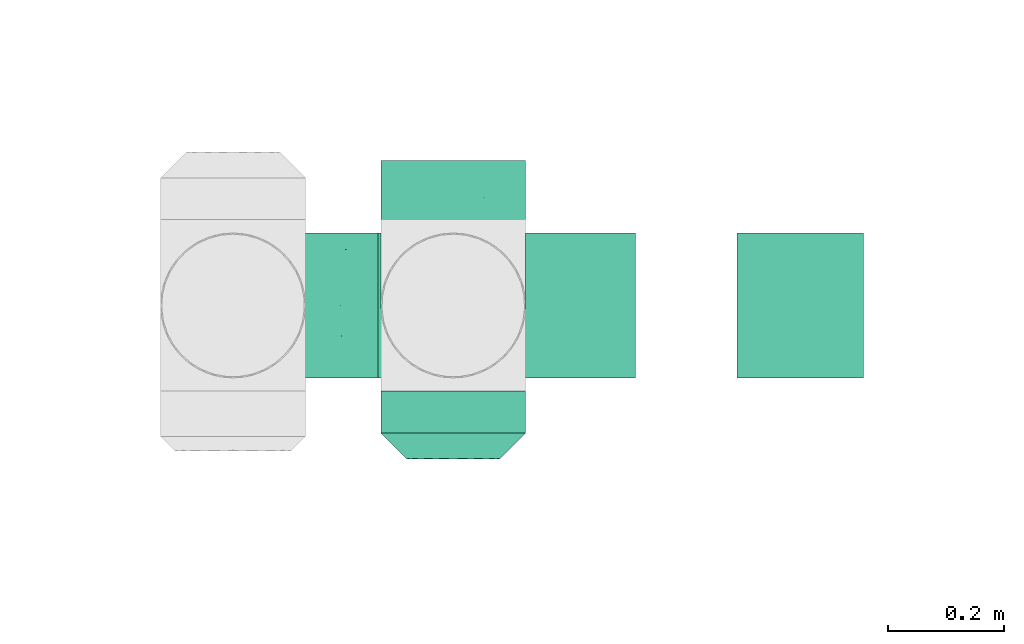
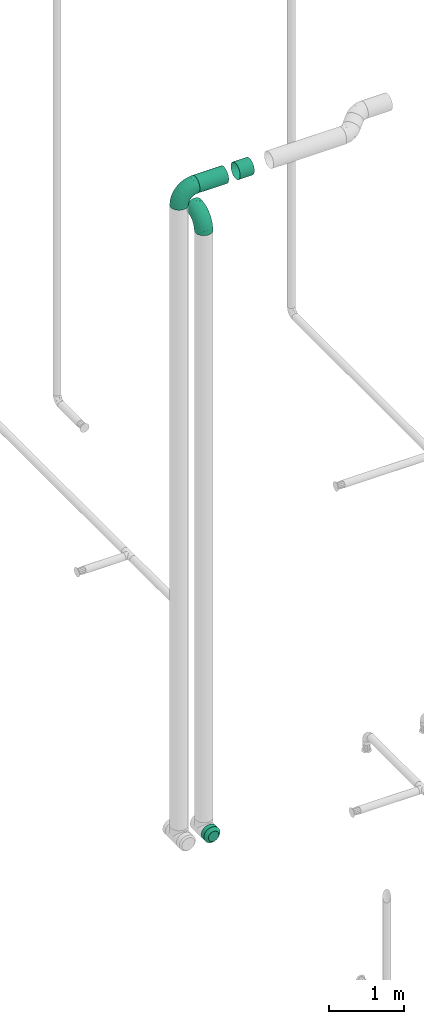
# One storey, part 48 of 123: 3 flow fittings, 2 flow segments.
"""IFC2X3 building model written with IfcOpenShell, lengths in millimetres."""

from ifc_helpers import new_model, entity, si_unit, converted_unit, derived_unit, direction, frame, origin_with_axes, origin_2d_with_axis, place, context, subcontext, project, spatial, hollow_circle, extrude, open_shell, surface_model, source, transform, mapped, material, layer, layer_set, layer_usage, type_object, element, save


model = new_model("IFC2X3")

# Units and contexts
model_context = context("Model", 3, precision=1e-05, world=origin_with_axes(), true_north=direction((0.0, 1.0)))
body_context = subcontext(model_context, "Body", "Model", "MODEL_VIEW")
ifc_project = project(units=[si_unit("AREAUNIT", "SQUARE_METRE"), si_unit("VOLUMEUNIT", "CUBIC_METRE", prefix="DECI"), si_unit("TIMEUNIT", "SECOND"), si_unit("THERMODYNAMICTEMPERATUREUNIT", "DEGREE_CELSIUS"), si_unit("PRESSUREUNIT", "PASCAL"), si_unit("MASSUNIT", "GRAM", prefix="KILO"), si_unit("LENGTHUNIT", "METRE", prefix="MILLI"), si_unit("POWERUNIT", "WATT"), si_unit("ELECTRICCURRENTUNIT", "AMPERE"), si_unit("ELECTRICVOLTAGEUNIT", "VOLT"), derived_unit("VOLUMETRICFLOWRATEUNIT", [(si_unit("VOLUMEUNIT", "CUBIC_METRE", prefix="DECI"), 1), (si_unit("TIMEUNIT", "SECOND"), -1)]), derived_unit("LINEARVELOCITYUNIT", [(si_unit("LENGTHUNIT", "METRE"), 1), (si_unit("TIMEUNIT", "SECOND"), -1)]), derived_unit("MASSDENSITYUNIT", [(si_unit("MASSUNIT", "GRAM", prefix="KILO"), 1), (si_unit("VOLUMEUNIT", "CUBIC_METRE"), -1)]), converted_unit("PLANEANGLEUNIT", "DEGREE", entity("IfcRatioMeasure", 0.01745), si_unit("PLANEANGLEUNIT", "RADIAN"), dimensions=[0, 0, 0, 0, 0, 0, 0])], contexts=[model_context])

# Site, building, storey
site_placement = place(None, origin_with_axes())
site = spatial("IfcSite", under=ifc_project, at=site_placement, CompositionType="ELEMENT")
building_placement = place(site_placement, origin_with_axes())
building = spatial("IfcBuilding", under=site, at=building_placement, Name="mc-building", CompositionType="ELEMENT")
storey_placement = place(building_placement, origin_with_axes())
storey = spatial("IfcBuildingStorey", under=building, at=storey_placement, Name="1. Korrus", CompositionType="ELEMENT", Elevation=0.0)

# Flow fittings
duct_fitting_type_1 = type_object("IfcDuctFittingType", PredefinedType="TRANSITION")
shared_shape_1 = source(origin_with_axes(), body_context, "Body", "SurfaceModel", [
    surface_model("IfcShellBasedSurfaceModel", [(117.0, 73.91036, -30.61467), (117.0, 30.61467, 73.91036), (117.0, 0.0, 80.0), (117.0, -30.61467, 73.91036), (117.0, -80.0, 0.0), (117.0, -56.56854, 56.56854), (117.0, 73.91036, 30.61467), (117.0, 56.56854, 56.56854), (117.0, 80.0, 0.0), (117.0, -73.91036, 30.61467), (117.0, -73.91036, -30.61467), (117.0, -56.56854, -56.56854), (117.0, 0.0, -80.0), (117.0, -30.61467, -73.91036), (117.0, 56.56854, -56.56854), (117.0, 30.61467, -73.91036), (72.0, 125.0, 0.0), (72.0, -38.62713, 118.88206), (72.0, 0.0, 125.0), (72.0, 73.47315, 101.12712), (72.0, 38.62713, 118.88206), (72.0, 101.12712, 73.47315), (72.0, -101.12712, 73.47315), (72.0, -73.47315, 101.12712), (72.0, -118.88206, -38.62713), (72.0, -118.88206, 38.62713), (72.0, -125.0, 0.0), (72.0, 118.88206, 38.62713), (72.0, 118.88206, -38.62713), (72.0, -38.62713, -118.88206), (72.0, 73.47315, -101.12712), (72.0, 101.12712, -73.47315), (72.0, 0.0, -125.0), (72.0, 38.62713, -118.88206), (72.0, -101.12712, -73.47315), (72.0, -73.47315, -101.12712), (117.0, 76.95518, -15.30734), (117.0, 43.59161, -65.23945), (117.0, -43.59161, -65.23945), (117.0, 15.30734, -76.95518), (117.0, 65.23945, -43.59161), (117.0, -15.30734, -76.95518), (117.0, -65.23945, -43.59161), (117.0, -76.95518, -15.30734), (117.0, -76.95518, 15.30734), (117.0, -43.59161, 65.23945), (117.0, 43.59161, 65.23945), (117.0, -15.30734, 76.95518), (117.0, -65.23945, 43.59161), (117.0, 15.30734, 76.95518), (117.0, 65.23945, 43.59161), (117.0, 76.95518, 15.30734), (117.0, 20.70552, -77.27406), (117.0, 40.0, -69.28203), (117.0, 69.28203, -40.0), (117.0, 77.27406, -20.70552), (117.0, -77.27406, -20.70552), (117.0, -20.70552, -77.27406), (117.0, -40.0, -69.28203), (117.0, -69.28203, -40.0), (117.0, 69.28203, 40.0), (117.0, 40.0, 69.28203), (117.0, 20.70552, 77.27406), (117.0, -77.27406, 20.70552), (117.0, -69.28203, 40.0), (117.0, -40.0, 69.28203), (117.0, -20.70552, 77.27406), (117.0, 77.27406, 20.70552), (115.0, 0.0, 80.0), (115.0, 20.70552, 77.27406), (115.0, 40.0, 69.28203), (115.0, -80.0, 0.0), (115.0, 56.56854, 56.56854), (115.0, 69.28203, -40.0), (115.0, 69.28203, 40.0), (115.0, -20.70552, 77.27406), (115.0, -56.56854, 56.56854), (115.0, -40.0, 69.28203), (115.0, -77.27406, 20.70552), (115.0, -69.28203, 40.0), (115.0, 77.27406, 20.70552), (115.0, 80.0, 0.0), (115.0, 77.27406, -20.70552), (115.0, -77.27406, -20.70552), (115.0, 56.56854, -56.56854), (115.0, 40.0, -69.28203), (115.0, 20.70552, -77.27406), (115.0, -56.56854, -56.56854), (115.0, -69.28203, -40.0), (115.0, -20.70552, -77.27406), (115.0, -40.0, -69.28203), (115.0, 0.0, -80.0), (0.0, 32.35238, 120.74073), (0.0, -32.35238, 120.74073), (0.0, 0.0, 125.0), (0.0, 88.38835, 88.38835), (0.0, 62.5, 108.25318), (0.0, 108.25318, 62.5), (0.0, -120.74073, -32.35238), (0.0, -88.38835, 88.38835), (0.0, -62.5, 108.25318), (0.0, -125.0, 0.0), (0.0, -120.74073, 32.35238), (0.0, -108.25318, 62.5), (0.0, 120.74073, 32.35238), (0.0, 120.74073, -32.35238), (0.0, -88.38835, -88.38835), (0.0, 125.0, 0.0), (0.0, 32.35238, -120.74073), (0.0, 108.25318, -62.5), (0.0, 88.38835, -88.38835), (0.0, 62.5, -108.25318), (0.0, -62.5, -108.25318), (0.0, -108.25318, -62.5), (0.0, 0.0, -125.0), (0.0, -32.35238, -120.74073), (72.0, 32.35238, -120.74073), (72.0, 62.5, -108.25318), (72.0, 88.38835, -88.38835), (72.0, 108.25318, -62.5), (72.0, 120.74073, -32.35238), (72.0, -62.5, -108.25318), (72.0, -32.35238, -120.74073), (72.0, -88.38835, -88.38835), (72.0, -120.74073, -32.35238), (72.0, -108.25318, -62.5), (72.0, 120.74073, 32.35238), (72.0, 108.25318, 62.5), (72.0, 32.35238, 120.74073), (72.0, 88.38835, 88.38835), (72.0, 62.5, 108.25318), (72.0, -120.74073, 32.35238), (72.0, -88.38835, 88.38835), (72.0, -108.25318, 62.5), (72.0, -32.35238, 120.74073), (72.0, -62.5, 108.25318)], [open_shell([[[0, 1, 2]], [[3, 4, 2]], [[3, 5, 4]], [[6, 7, 0]], [[0, 8, 6]], [[1, 0, 7]], [[5, 9, 4]], [[4, 10, 11]], [[4, 11, 12]], [[12, 11, 13]], [[14, 0, 15]], [[12, 15, 0]], [[0, 4, 12]], [[4, 0, 2]], [[16, 17, 18]], [[19, 16, 20]], [[20, 16, 18]], [[19, 21, 16]], [[22, 23, 24]], [[22, 24, 25]], [[17, 24, 23]], [[25, 24, 26]], [[27, 16, 21]], [[24, 16, 28]], [[29, 28, 30]], [[30, 28, 31]], [[32, 30, 33]], [[24, 28, 34]], [[34, 29, 35]], [[28, 29, 34]], [[30, 32, 29]], [[16, 24, 17]], [[16, 36, 28]], [[37, 15, 30]], [[38, 11, 35]], [[39, 12, 32]], [[31, 0, 40]], [[32, 33, 39]], [[30, 14, 37]], [[14, 30, 31]], [[41, 32, 12]], [[33, 15, 39]], [[40, 14, 31]], [[15, 33, 30]], [[34, 11, 42]], [[36, 16, 8]], [[32, 41, 29]], [[13, 35, 29]], [[26, 43, 4]], [[10, 34, 42]], [[35, 13, 38]], [[36, 0, 28]], [[34, 35, 11]], [[24, 34, 10]], [[41, 13, 29]], [[24, 43, 26]], [[0, 31, 28]], [[24, 10, 43]], [[26, 44, 25]], [[45, 3, 23]], [[46, 7, 19]], [[47, 2, 18]], [[22, 9, 48]], [[18, 17, 47]], [[23, 5, 45]], [[5, 23, 22]], [[49, 18, 2]], [[17, 3, 47]], [[48, 5, 22]], [[3, 17, 23]], [[21, 7, 50]], [[44, 26, 4]], [[18, 49, 20]], [[1, 19, 20]], [[16, 51, 8]], [[6, 21, 50]], [[19, 1, 46]], [[44, 9, 25]], [[21, 19, 7]], [[27, 21, 6]], [[49, 1, 20]], [[27, 51, 16]], [[9, 22, 25]], [[27, 6, 51]], [[52, 53, 14]], [[52, 14, 54]], [[54, 55, 8]], [[56, 52, 4]], [[54, 4, 52]], [[57, 11, 58]], [[57, 12, 52]], [[11, 56, 59]], [[11, 57, 52]], [[56, 11, 52]], [[54, 8, 60]], [[60, 7, 54]], [[4, 54, 7]], [[61, 62, 2]], [[7, 61, 63]], [[2, 5, 61]], [[63, 5, 64]], [[63, 4, 7]], [[2, 65, 5]], [[63, 61, 5]], [[66, 65, 2]], [[60, 8, 67]], [[68, 69, 70]], [[71, 68, 70]], [[72, 73, 70]], [[73, 71, 70]], [[72, 74, 73]], [[75, 76, 77]], [[75, 68, 76]], [[76, 78, 79]], [[76, 68, 78]], [[71, 78, 68]], [[74, 80, 81]], [[81, 82, 73]], [[71, 73, 83]], [[84, 85, 86]], [[84, 86, 73]], [[83, 73, 86]], [[83, 87, 88]], [[83, 86, 87]], [[87, 89, 90]], [[86, 89, 87]], [[86, 91, 89]], [[73, 74, 81]], [[83, 56, 71]], [[88, 59, 83]], [[58, 87, 90]], [[88, 87, 11]], [[57, 90, 89]], [[83, 59, 56]], [[56, 4, 71]], [[57, 58, 90]], [[11, 87, 58]], [[11, 59, 88]], [[12, 57, 89]], [[89, 91, 12]], [[86, 52, 91]], [[85, 53, 86]], [[54, 84, 73]], [[85, 84, 14]], [[55, 73, 82]], [[85, 14, 53]], [[53, 52, 86]], [[8, 55, 82]], [[54, 73, 55]], [[54, 14, 84]], [[81, 8, 82]], [[91, 52, 12]], [[80, 67, 81]], [[74, 60, 80]], [[61, 72, 70]], [[74, 72, 7]], [[62, 70, 69]], [[80, 60, 67]], [[67, 8, 81]], [[62, 61, 70]], [[7, 72, 61]], [[7, 60, 74]], [[2, 62, 69]], [[69, 68, 2]], [[75, 66, 68]], [[77, 65, 75]], [[64, 76, 79]], [[77, 76, 5]], [[63, 79, 78]], [[77, 5, 65]], [[65, 66, 75]], [[71, 4, 63]], [[64, 79, 63]], [[64, 5, 76]], [[78, 71, 63]], [[68, 66, 2]], [[92, 93, 94]], [[95, 92, 96]], [[93, 95, 97]], [[92, 95, 93]], [[97, 98, 93]], [[93, 99, 100]], [[99, 93, 101]], [[99, 102, 103]], [[102, 99, 101]], [[101, 93, 98]], [[97, 104, 98]], [[105, 106, 107]], [[108, 105, 109]], [[110, 111, 108]], [[110, 108, 109]], [[112, 105, 108]], [[98, 106, 113]], [[104, 106, 98]], [[112, 114, 115]], [[106, 105, 112]], [[108, 114, 112]], [[106, 104, 107]], [[116, 117, 118]], [[116, 118, 119]], [[116, 120, 121]], [[120, 116, 119]], [[121, 120, 16]], [[32, 121, 122]], [[32, 116, 121]], [[123, 124, 125]], [[126, 123, 121]], [[26, 124, 123]], [[126, 121, 16]], [[127, 26, 126]], [[128, 127, 129]], [[127, 128, 26]], [[128, 129, 130]], [[18, 26, 128]], [[131, 132, 133]], [[132, 131, 26]], [[132, 134, 135]], [[134, 132, 26]], [[26, 18, 134]], [[126, 26, 123]], [[98, 124, 101]], [[113, 125, 98]], [[113, 106, 123]], [[106, 112, 121]], [[98, 125, 124]], [[124, 26, 101]], [[32, 122, 115]], [[115, 122, 121]], [[123, 106, 121]], [[123, 125, 113]], [[112, 115, 121]], [[115, 114, 32]], [[116, 108, 111]], [[110, 117, 111]], [[119, 109, 105]], [[110, 109, 118]], [[120, 105, 107]], [[108, 116, 32]], [[111, 117, 116]], [[110, 118, 117]], [[109, 119, 118]], [[120, 119, 105]], [[107, 16, 120]], [[108, 32, 114]], [[104, 126, 107]], [[97, 127, 104]], [[92, 94, 128]], [[95, 129, 97]], [[104, 127, 126]], [[126, 16, 107]], [[130, 96, 128]], [[130, 129, 95]], [[96, 92, 128]], [[129, 127, 97]], [[95, 96, 130]], [[94, 18, 128]], [[134, 93, 100]], [[99, 135, 100]], [[133, 103, 102]], [[99, 103, 132]], [[131, 102, 101]], [[93, 134, 18]], [[100, 135, 134]], [[99, 132, 135]], [[103, 133, 132]], [[131, 133, 102]], [[101, 26, 131]], [[93, 18, 94]]])]),
])
flow_fitting_placement = place(storey_placement, frame((7563.36286, 7527.18604, -570.0), z_axis=(0.0, 0.0, 1.0), x_axis=(0.0, -1.0, 0.0)))
element("IfcFlowFitting", 1, at=flow_fitting_placement, inside=storey, type_object=duct_fitting_type_1, context=body_context, shape_type="MappedRepresentation", body=[
    mapped(shared_shape_1, transform((0.0, 0.0, 0.0), scale=1.0)),
])
duct_fitting_type_2 = type_object("IfcDuctFittingType", Name="BU", PredefinedType="BEND")
shared_shape_2 = source(origin_with_axes(), body_context, "Body", "SurfaceModel", [
    surface_model("IfcShellBasedSurfaceModel", [(-250.0, 0.0, -125.0), (-250.0, -32.35238, -120.74073), (-250.0, 32.35238, -120.74073), (-250.0, 120.74073, 32.35238), (-250.0, 62.5, -108.25318), (-250.0, 108.25318, -62.5), (-250.0, 88.38835, -88.38835), (-250.0, -125.0, 0.0), (-250.0, -120.74073, 32.35238), (-250.0, -88.38835, -88.38835), (-250.0, -62.5, -108.25318), (-250.0, -120.74073, -32.35238), (-250.0, -108.25318, -62.5), (-250.0, 120.74073, -32.35238), (-250.0, 108.25318, 62.5), (-250.0, 88.38835, 88.38835), (-250.0, 32.35238, 120.74073), (-250.0, 62.5, 108.25318), (-250.0, 0.0, 125.0), (-250.0, -108.25318, 62.5), (-250.0, -88.38835, 88.38835), (-250.0, -32.35238, 120.74073), (-250.0, -62.5, 108.25318), (-250.0, 125.0, 0.0), (-32.35238, 250.0, -120.74073), (-125.0, 250.0, 0.0), (0.0, 250.0, -125.0), (-62.5, 250.0, -108.25318), (-88.38835, 250.0, -88.38835), (-108.25318, 250.0, -62.5), (88.38835, 250.0, -88.38835), (120.74073, 250.0, 32.35238), (62.5, 250.0, -108.25318), (32.35238, 250.0, -120.74073), (108.25318, 250.0, -62.5), (120.74073, 250.0, -32.35238), (125.0, 250.0, 0.0), (-120.74073, 250.0, -32.35238), (-120.74073, 250.0, 32.35238), (-108.25318, 250.0, 62.5), (-88.38835, 250.0, 88.38835), (-32.35238, 250.0, 120.74073), (-62.5, 250.0, 108.25318), (62.5, 250.0, 108.25318), (108.25318, 250.0, 62.5), (88.38835, 250.0, 88.38835), (32.35238, 250.0, 120.74073), (0.0, 250.0, 125.0), (-117.1466, 118.31037, 107.99909), (-96.3976, 96.3976, 120.62713), (-81.83105, 144.33246, 113.94821), (-194.36977, 6.26802, 125.0), (-210.4208, 30.62363, 122.03104), (-141.52906, 24.75778, 125.0), (-170.49386, 38.98103, 122.57548), (-119.6899, 216.62967, 47.83543), (-24.75778, 141.52906, 125.0), (-58.72535, 129.81418, 122.65468), (-54.54213, 94.12755, 125.0), (-164.16498, 126.25836, 75.79028), (-183.25942, 133.03051, 48.20921), (-192.36733, 110.61415, 76.09518), (-129.81418, 58.72535, 122.65468), (-136.01097, 136.01098, 87.97963), (-106.86909, 152.6368, 98.55189), (-123.74113, 163.86567, 78.64582), (-94.12755, 54.54213, 125.0), (-55.07783, 196.37292, 115.48494), (-30.62363, 210.4208, 122.03104), (-80.06444, 213.05689, 99.16916), (-216.62967, 119.68991, 47.83543), (-223.32127, 101.54736, 76.09518), (-226.00176, 125.30303, 22.18937), (-213.05689, 80.06444, 99.16916), (-38.98103, 170.49388, 122.57548), (-167.42296, 153.3147, 23.08194), (-162.69986, 162.69986, 0.0), (-176.52685, 148.87287, 0.0), (-131.11793, 211.37287, 0.0), (-131.91505, 201.08762, 26.37495), (-125.30889, 225.96459, 22.19643), (-196.37292, 55.07783, 115.48495), (-167.53374, 99.7969, 97.1574), (-144.33245, 81.83105, 113.94821), (-82.81251, 177.89548, 104.93319), (-133.0305, 183.25942, 48.20921), (-110.61415, 192.36733, 76.09518), (-101.54736, 223.32127, 76.09518), (-150.35937, 170.37352, 25.11258), (-148.87287, 176.52685, 0.0), (-188.58367, 138.9352, 21.795), (-139.99541, 193.94986, 0.0), (-144.89628, 149.85264, 68.09613), (-6.26802, 194.36977, 125.0), (-155.58398, 155.58398, 45.37002), (-211.37287, 131.11793, 0.0), (-136.01097, 136.01098, -87.97963), (-152.6368, 106.86909, -98.55189), (-163.86567, 123.74113, -78.64581), (-225.96459, 125.30889, -22.19643), (-192.36733, 110.61415, -76.09518), (-223.32127, 101.54736, -76.09518), (-216.62967, 119.68991, -47.83543), (-118.31037, 117.14661, -107.99909), (-170.37352, 150.35937, -25.11258), (-183.25942, 133.03051, -48.20921), (-119.6899, 216.62967, -47.83543), (-133.0305, 183.25942, -48.20921), (-138.9352, 188.58369, -21.795), (-213.05689, 80.06444, -99.16916), (-196.37292, 55.07783, -115.48495), (-201.08762, 131.91505, -26.37495), (-193.94986, 139.99541, 0.0), (-129.81418, 58.72535, -122.65468), (-170.49386, 38.98103, -122.57548), (-144.33245, 81.83105, -113.94821), (-210.4208, 30.62363, -122.03104), (-126.25836, 164.16498, -75.79028), (-99.7969, 167.53376, -97.1574), (-81.83105, 144.33246, -113.94821), (-96.3976, 96.3976, -120.62713), (-55.07783, 196.37292, -115.48494), (-30.62363, 210.4208, -122.03104), (-38.98103, 170.49388, -122.57548), (-177.89548, 82.81251, -104.93319), (-153.3147, 167.42296, -23.08194), (-94.12755, 54.54213, -125.0), (-141.52906, 24.75778, -125.0), (-101.54736, 223.32127, -76.09518), (-80.06444, 213.05689, -99.16916), (-125.30303, 226.00176, -22.18937), (-54.54213, 94.12755, -125.0), (-24.75778, 141.52906, -125.0), (-58.72535, 129.81418, -122.65468), (-110.61415, 192.36733, -76.09518), (-6.26802, 194.36977, -125.0), (-149.85264, 144.89629, -68.09613), (-194.36977, 6.26802, -125.0), (-155.58398, 155.58398, -45.37002), (-193.89957, -74.54276, -96.57977), (-62.5, -74.75953, 0.0), (-121.74244, -102.38473, 0.0), (-94.73344, -89.12736, -22.37394), (119.30291, 184.88194, 0.0), (109.25277, 157.04874, -31.04738), (-53.59476, 53.59477, -121.8788), (-9.37807, 56.98679, -110.48256), (-81.86678, 3.72743, -115.33626), (-145.59015, -7.38807, -121.8788), (-12.03452, 12.03453, -90.20459), (23.00116, 67.52551, -97.38178), (40.98911, 53.20617, -73.25276), (-159.90694, -102.02588, -52.64847), (81.22573, 100.98341, -53.01017), (92.95193, 171.4026, -72.47744), (107.80964, 186.67175, -52.65074), (13.81192, -13.81192, -21.78849), (8.88806, -8.88806, -46.26498), (55.09242, 37.49634, -28.07964), (-184.88194, -119.30291, 0.0), (87.32054, 94.83884, -30.20715), (49.0818, 42.5299, -51.28061), (-171.40262, -92.95193, -72.47744), (-3.30282, -3.44047, -69.82022), (-100.98341, -81.22573, -53.01016), (37.26667, 8.95465, 0.0), (-8.95465, -37.26667, 0.0), (-37.49634, -55.09242, -28.07964), (46.65178, 188.51647, -113.22824), (-157.04874, -109.25277, -31.04738), (16.88787, 136.38295, -118.40506), (-42.32523, -45.52951, -57.0897), (-69.83191, -18.55522, -101.18597), (-150.46416, -40.11916, -111.39103), (-60.46923, -37.78604, -81.71663), (74.54276, 193.89959, -96.57977), (102.38473, 121.74244, 0.0), (74.75953, 62.5, 0.0), (36.31281, 122.56516, -107.73314), (-124.37151, -58.88278, -93.06207), (-111.05914, -71.02736, -75.26007), (71.09889, 111.35886, -75.33067), (58.88278, 124.37151, -93.06207), (-157.04874, -109.25277, 31.04738), (-53.20616, -40.9891, 73.25276), (3.44048, 3.30283, 69.82022), (-12.03452, 12.03453, 90.20459), (55.09242, 37.49634, 28.07964), (-37.49634, -55.09242, 28.07964), (-94.83884, -87.32054, 30.20715), (-67.52551, -23.00116, 97.38178), (-186.67175, -107.80965, 52.65074), (7.38807, 145.59015, 121.8788), (-42.5299, -49.0818, 51.28061), (-53.59476, 53.59477, 121.8788), (-56.98679, 9.37808, 110.48256), (-3.72743, 81.86679, 115.33626), (13.81192, -13.81192, 21.78849), (-188.51647, -46.65178, 113.22824), (-136.38295, -16.88787, 118.40506), (-171.40262, -92.95193, 72.47744), (40.11916, 150.46417, 111.39103), (-122.56517, -36.31281, 107.73314), (92.95193, 171.4026, 72.47744), (37.78605, 60.46924, 81.71663), (-193.89957, -74.54276, 96.57977), (8.88806, -8.88806, 46.26498), (109.25277, 157.04874, 31.04738), (89.12736, 94.73344, 22.37394), (18.55523, 69.83191, 101.18597), (-100.98341, -81.22573, 53.01016), (102.02588, 159.90694, 52.64847), (81.22573, 100.98341, 53.01017), (74.54276, 193.89959, 96.57977), (45.52951, 42.32523, 57.0897), (58.88278, 124.37151, 93.06207), (-111.35886, -71.09889, 75.33067), (-124.37151, -58.88278, 93.06207), (71.02736, 111.05915, 75.26008)], [open_shell([[[0, 1, 2]], [[2, 3, 4]], [[5, 6, 3]], [[3, 6, 4]], [[2, 7, 8]], [[9, 7, 10]], [[2, 1, 10]], [[11, 7, 12]], [[9, 12, 7]], [[10, 7, 2]], [[13, 5, 3]], [[14, 3, 2]], [[14, 2, 15]], [[2, 16, 17]], [[17, 15, 2]], [[16, 2, 18]], [[19, 20, 2]], [[2, 8, 19]], [[21, 18, 22]], [[20, 22, 18]], [[18, 2, 20]], [[23, 13, 3]], [[24, 25, 26]], [[27, 25, 24]], [[25, 28, 29]], [[27, 28, 25]], [[30, 26, 31]], [[26, 30, 32]], [[32, 33, 26]], [[30, 31, 34]], [[35, 34, 31]], [[35, 31, 36]], [[37, 25, 29]], [[38, 39, 26]], [[39, 40, 26]], [[41, 26, 42]], [[26, 40, 42]], [[43, 26, 41]], [[44, 31, 26]], [[45, 44, 26]], [[41, 46, 43]], [[45, 26, 43]], [[46, 41, 47]], [[38, 26, 25]], [[48, 49, 50]], [[18, 51, 52]], [[51, 53, 54]], [[39, 38, 55]], [[56, 57, 58]], [[59, 60, 61]], [[57, 49, 58]], [[54, 53, 62]], [[63, 64, 65]], [[62, 53, 66]], [[67, 68, 41]], [[42, 40, 69]], [[70, 14, 71]], [[3, 72, 23]], [[70, 3, 14]], [[73, 15, 17]], [[57, 74, 50]], [[14, 15, 71]], [[75, 76, 77]], [[42, 69, 67]], [[58, 49, 66]], [[78, 79, 80]], [[16, 81, 17]], [[82, 73, 81]], [[74, 68, 67]], [[49, 48, 83]], [[81, 52, 54]], [[42, 67, 41]], [[41, 68, 47]], [[60, 70, 61]], [[72, 3, 70]], [[84, 67, 69]], [[85, 86, 55]], [[87, 40, 39]], [[88, 89, 76]], [[64, 63, 48]], [[59, 82, 63]], [[17, 81, 73]], [[25, 78, 80]], [[86, 87, 55]], [[70, 60, 90]], [[62, 49, 83]], [[82, 81, 83]], [[60, 75, 90]], [[71, 73, 61]], [[79, 91, 88]], [[87, 69, 40]], [[86, 64, 84]], [[92, 59, 63]], [[76, 75, 88]], [[78, 91, 79]], [[65, 92, 63]], [[49, 62, 66]], [[54, 83, 81]], [[83, 54, 62]], [[81, 16, 52]], [[74, 57, 56]], [[49, 57, 50]], [[93, 74, 56]], [[50, 74, 67]], [[18, 52, 16]], [[51, 54, 52]], [[74, 93, 68]], [[47, 68, 93]], [[73, 71, 15]], [[70, 71, 61]], [[55, 87, 39]], [[69, 87, 86]], [[64, 48, 50]], [[48, 63, 82]], [[84, 64, 50]], [[65, 64, 86]], [[67, 84, 50]], [[86, 84, 69]], [[86, 85, 65]], [[92, 85, 94]], [[85, 92, 65]], [[59, 94, 60]], [[59, 92, 94]], [[82, 59, 61]], [[73, 82, 61]], [[82, 83, 48]], [[94, 88, 75]], [[90, 75, 77]], [[60, 94, 75]], [[77, 95, 90]], [[90, 95, 72]], [[94, 85, 88]], [[88, 91, 89]], [[79, 88, 85]], [[85, 55, 79]], [[80, 79, 55]], [[55, 38, 80]], [[25, 80, 38]], [[90, 72, 70]], [[23, 72, 95]], [[96, 97, 98]], [[23, 95, 99]], [[100, 101, 102]], [[97, 96, 103]], [[104, 77, 76]], [[100, 102, 105]], [[5, 13, 102]], [[101, 6, 5]], [[106, 107, 108]], [[4, 109, 110]], [[111, 112, 104]], [[113, 114, 115]], [[4, 110, 2]], [[2, 116, 0]], [[117, 118, 96]], [[114, 116, 110]], [[103, 119, 120]], [[121, 122, 123]], [[110, 109, 124]], [[125, 76, 89]], [[126, 127, 113]], [[100, 97, 124]], [[128, 29, 28]], [[4, 6, 109]], [[29, 106, 37]], [[129, 28, 27]], [[24, 121, 27]], [[106, 29, 128]], [[37, 130, 25]], [[110, 116, 2]], [[95, 111, 99]], [[118, 129, 121]], [[27, 121, 129]], [[126, 120, 131]], [[123, 132, 133]], [[125, 108, 107]], [[117, 107, 134]], [[103, 120, 115]], [[26, 135, 122]], [[135, 132, 123]], [[132, 131, 133]], [[113, 120, 126]], [[130, 37, 106]], [[133, 120, 119]], [[101, 109, 6]], [[107, 106, 134]], [[118, 121, 119]], [[128, 129, 134]], [[95, 112, 111]], [[98, 136, 96]], [[136, 117, 96]], [[76, 125, 104]], [[114, 113, 127]], [[120, 113, 115]], [[137, 114, 127]], [[115, 114, 110]], [[120, 133, 131]], [[123, 119, 121]], [[119, 123, 133]], [[121, 24, 122]], [[114, 137, 116]], [[0, 116, 137]], [[26, 122, 24]], [[135, 123, 122]], [[102, 101, 5]], [[109, 101, 100]], [[129, 128, 28]], [[106, 128, 134]], [[97, 103, 115]], [[103, 96, 118]], [[124, 97, 115]], [[98, 97, 100]], [[110, 124, 115]], [[100, 124, 109]], [[100, 105, 98]], [[136, 105, 138]], [[105, 136, 98]], [[117, 138, 107]], [[117, 136, 138]], [[118, 117, 134]], [[129, 118, 134]], [[118, 119, 103]], [[138, 104, 125]], [[108, 125, 89]], [[107, 138, 125]], [[89, 78, 108]], [[108, 78, 130]], [[138, 105, 104]], [[104, 112, 77]], [[111, 104, 105]], [[105, 102, 111]], [[99, 111, 102]], [[102, 13, 99]], [[23, 99, 13]], [[108, 130, 106]], [[25, 130, 78]], [[139, 9, 10]], [[140, 141, 142]], [[35, 143, 144]], [[127, 126, 145]], [[126, 131, 145]], [[145, 146, 147]], [[137, 148, 0]], [[149, 150, 151]], [[127, 145, 148]], [[152, 11, 12]], [[153, 154, 155]], [[156, 157, 158]], [[159, 7, 11]], [[144, 160, 153]], [[161, 158, 157]], [[152, 12, 162]], [[151, 161, 163]], [[152, 162, 164]], [[156, 165, 166]], [[142, 164, 167]], [[168, 33, 32]], [[141, 159, 169]], [[142, 141, 169]], [[127, 148, 137]], [[132, 170, 145]], [[171, 167, 164]], [[135, 170, 132]], [[0, 148, 1]], [[147, 172, 173]], [[170, 135, 33]], [[168, 170, 33]], [[132, 145, 131]], [[173, 148, 147]], [[1, 148, 173]], [[149, 163, 174]], [[33, 135, 26]], [[146, 145, 170]], [[34, 155, 154]], [[30, 175, 32]], [[156, 166, 167]], [[160, 176, 177]], [[149, 174, 172]], [[160, 177, 158]], [[154, 30, 34]], [[162, 12, 9]], [[36, 143, 35]], [[165, 158, 177]], [[144, 143, 176]], [[35, 144, 155]], [[140, 167, 166]], [[146, 178, 150]], [[147, 148, 145]], [[159, 11, 169]], [[151, 163, 149]], [[178, 170, 168]], [[172, 146, 149]], [[139, 173, 179]], [[1, 173, 10]], [[139, 162, 9]], [[180, 179, 174]], [[181, 153, 151]], [[175, 154, 182]], [[175, 168, 32]], [[168, 175, 178]], [[150, 178, 182]], [[146, 170, 178]], [[182, 154, 181]], [[146, 150, 149]], [[182, 151, 150]], [[153, 160, 161]], [[157, 156, 167]], [[165, 156, 158]], [[157, 171, 163]], [[174, 179, 172]], [[171, 174, 163]], [[179, 180, 162]], [[173, 172, 179]], [[146, 172, 147]], [[167, 171, 157]], [[171, 164, 180]], [[171, 180, 174]], [[164, 162, 180]], [[154, 175, 30]], [[175, 182, 178]], [[173, 139, 10]], [[162, 139, 179]], [[164, 142, 169]], [[140, 142, 167]], [[163, 161, 157]], [[151, 153, 161]], [[176, 160, 144]], [[161, 160, 158]], [[164, 169, 152]], [[152, 169, 11]], [[35, 155, 34]], [[153, 155, 144]], [[153, 181, 154]], [[151, 182, 181]], [[183, 159, 141]], [[159, 8, 7]], [[184, 185, 186]], [[187, 165, 177]], [[140, 188, 189]], [[186, 190, 184]], [[183, 191, 8]], [[56, 192, 93]], [[185, 184, 193]], [[189, 141, 140]], [[194, 195, 196]], [[197, 188, 166]], [[198, 199, 21]], [[191, 200, 19]], [[46, 192, 201]], [[195, 202, 190]], [[203, 44, 45]], [[51, 18, 21]], [[198, 21, 22]], [[199, 53, 51]], [[21, 199, 51]], [[53, 194, 66]], [[196, 192, 194]], [[186, 185, 204]], [[166, 188, 140]], [[200, 20, 19]], [[205, 22, 20]], [[188, 197, 206]], [[176, 143, 207]], [[208, 176, 207]], [[143, 36, 31]], [[186, 204, 209]], [[183, 189, 210]], [[203, 211, 44]], [[177, 176, 208]], [[187, 208, 212]], [[187, 197, 165]], [[212, 211, 203]], [[58, 192, 56]], [[194, 58, 66]], [[47, 192, 46]], [[196, 209, 201]], [[211, 31, 44]], [[194, 192, 58]], [[8, 159, 183]], [[93, 192, 47]], [[143, 31, 207]], [[194, 53, 199]], [[45, 43, 213]], [[210, 200, 191]], [[193, 188, 206]], [[196, 201, 192]], [[214, 187, 212]], [[195, 194, 199]], [[202, 199, 198]], [[209, 195, 186]], [[213, 201, 215]], [[46, 201, 43]], [[216, 210, 184]], [[205, 200, 217]], [[213, 203, 45]], [[218, 215, 204]], [[205, 198, 22]], [[198, 205, 202]], [[190, 202, 217]], [[195, 199, 202]], [[217, 200, 216]], [[195, 190, 186]], [[217, 184, 190]], [[210, 189, 193]], [[165, 197, 166]], [[206, 197, 187]], [[206, 214, 185]], [[204, 215, 209]], [[214, 204, 185]], [[215, 218, 203]], [[201, 209, 215]], [[195, 209, 196]], [[187, 214, 206]], [[214, 212, 218]], [[214, 218, 204]], [[212, 203, 218]], [[200, 205, 20]], [[205, 217, 202]], [[201, 213, 43]], [[203, 213, 215]], [[185, 193, 206]], [[184, 210, 193]], [[141, 189, 183]], [[193, 189, 188]], [[212, 208, 207]], [[177, 208, 187]], [[8, 191, 19]], [[210, 191, 183]], [[212, 207, 211]], [[211, 207, 31]], [[210, 216, 200]], [[184, 217, 216]]])]),
])
for number, where, z_axis, x_axis, name in (
    (2, (7183.36286, 7675.18604, 9914.30701), (0.0, 1.0, 0.0), (0.0, 0.0, 1.0), "BU"),
    (3, (7563.36286, 7675.18604, 9368.0), (-1.0, 0.0, 0.0), (0.0, 0.0, 1.0), "BU"),
):
    element("IfcFlowFitting", number, at=place(storey_placement, frame(where, z_axis=z_axis, x_axis=x_axis)), inside=storey, type_object=duct_fitting_type_2, Name=name, context=body_context, shape_type="MappedRepresentation", body=[
        mapped(shared_shape_2, transform((0.0, 0.0, 0.0), scale=1.0)),
    ])

# Flow segments
ifc_material = material(Name="FZ1")
ifc_layer = layer(ifc_material, 0.0)
ifc_layer_set = layer_set([ifc_layer], Name="FZ1")
ifc_layer_usage = layer_usage(ifc_layer_set, "AXIS1", "POSITIVE", 0.0)
duct_segment_type = type_object("IfcDuctSegmentType", Name="Safe", PredefinedType="RIGIDSEGMENT")
shared_shape_3 = source(origin_with_axes(), body_context, "Body", "SweptSolid", [
    extrude(hollow_circle(Radius=125.0, WallThickness=2.0, at=origin_2d_with_axis()), frame((0.0, 0.0, 0.0), z_axis=(1.0, 0.0, 0.0), x_axis=(0.0, 1.0, 0.0)), (0.0, 0.0, 1.0), 444.3),
])
flow_segment_1_placement = place(storey_placement, frame((7877.62654, 7675.18604, 9914.30701), z_axis=(0.0, 0.0, 1.0), x_axis=(-1.0, 0.0, 0.0)))
element("IfcFlowSegment", 4, at=flow_segment_1_placement, inside=storey, type_object=duct_segment_type, material=ifc_layer_usage, Name="Safe", context=body_context, shape_type="MappedRepresentation", body=[
    mapped(shared_shape_3, transform((0.0, 0.0, 0.0), scale=1.0)),
])
shared_shape_4 = source(origin_with_axes(), body_context, "Body", "SweptSolid", [
    extrude(hollow_circle(Radius=125.0, WallThickness=2.0, at=origin_2d_with_axis()), frame((0.0, 0.0, 0.0), z_axis=(1.0, 0.0, 0.0), x_axis=(0.0, 1.0, 0.0)), (0.0, 0.0, 1.0), 218.4),
])
flow_segment_2_placement = place(storey_placement, frame((8052.62654, 7675.18604, 9914.30701), z_axis=(0.0, 0.0, 1.0), x_axis=(1.0, 0.0, 0.0)))
element("IfcFlowSegment", 5, at=flow_segment_2_placement, inside=storey, type_object=duct_segment_type, material=ifc_layer_usage, Name="Safe", context=body_context, shape_type="MappedRepresentation", body=[
    mapped(shared_shape_4, transform((0.0, 0.0, 0.0), scale=1.0)),
])

save(model, "model.ifc")
